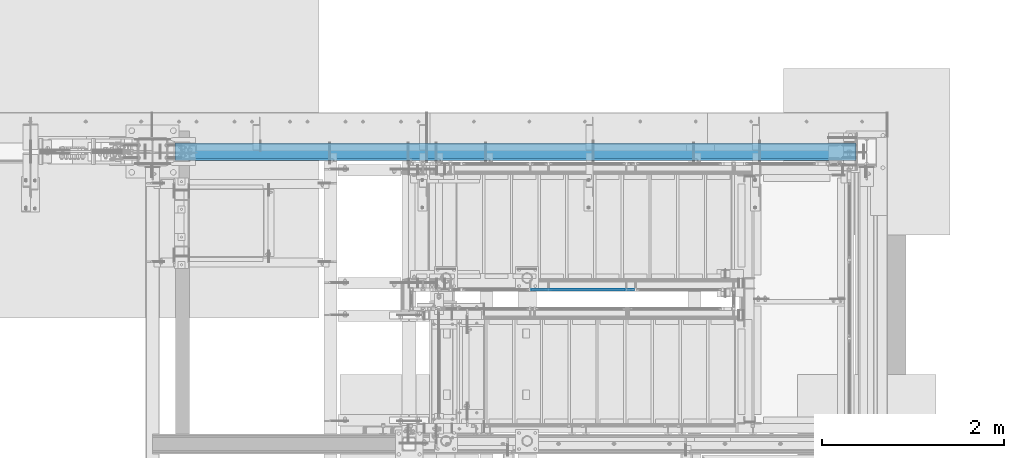
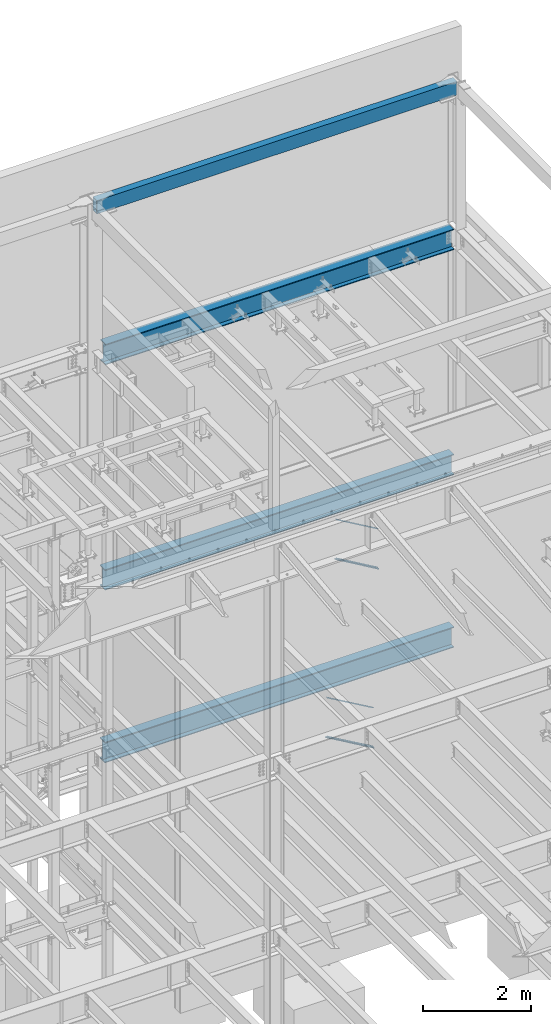
# One storey, part 793 of 1179: 8 beams, 2 members, 6 elements without a shape of their own.
"""IFC2X3 building model written with IfcOpenShell, lengths in millimetres."""

from ifc_helpers import new_model, si_unit, frame, origin_with_axes, place, context, subcontext, project, spatial, faceted_brep, material, type_object, element, aggregate, save


model = new_model("IFC2X3")

# Units and contexts
model_context = context("Model", 3, precision=1e-05, world=origin_with_axes())
body_context = subcontext(model_context, "Body", "Model", "MODEL_VIEW")
ifc_project = project(units=[si_unit("LENGTHUNIT", "METRE", prefix="MILLI"), si_unit("AREAUNIT", "SQUARE_METRE"), si_unit("VOLUMEUNIT", "CUBIC_METRE"), si_unit("MASSUNIT", "GRAM", prefix="KILO"), si_unit("TIMEUNIT", "SECOND"), si_unit("PLANEANGLEUNIT", "RADIAN"), si_unit("SOLIDANGLEUNIT", "STERADIAN"), si_unit("THERMODYNAMICTEMPERATUREUNIT", "DEGREE_CELSIUS"), si_unit("LUMINOUSINTENSITYUNIT", "LUMEN")], contexts=[model_context])

# Site, building, storey
site_placement = place(None, origin_with_axes())
site = spatial("IfcSite", under=ifc_project, at=site_placement, CompositionType="ELEMENT")
building_placement = place(site_placement, origin_with_axes())
building = spatial("IfcBuilding", under=site, at=building_placement, Name="Undefined", CompositionType="ELEMENT")
storey_placement = place(building_placement, origin_with_axes())
storey = spatial("IfcBuildingStorey", under=building, at=storey_placement, Name="Undefined", CompositionType="ELEMENT", Elevation=0.0)

# Assembly, beams
assembly_1_placement = place(storey_placement, origin_with_axes())
assembly_1 = element("IfcElementAssembly", 1, at=assembly_1_placement, inside=storey, Name="GUARDRAIL", AssemblyPlace="NOTDEFINED", PredefinedType="RIGID_FRAME")
ifc_material_1 = material(Name="STEEL/BUY-OUT")
beam_type_1 = type_object("IfcBeamType", PredefinedType="NOTDEFINED")
beam_1_placement = place(assembly_1_placement, frame((21301.2621914771, 39677.9751661883, 7438.18027204418), z_axis=(0.863778851027978, 0.0, -0.503871111016285), x_axis=(-0.503871111016286, 0.0, -0.863778851027978)))
beam_1 = element("IfcBeam", 2, at=beam_1_placement, type_object=beam_type_1, material=ifc_material_1, Name="U-EDGE", context=body_context, shape_type="Brep", body=[
    faceted_brep([(5.85307134315372e-07, 7.9375000095315, 493.146654191507), (25.4000002943358, 7.93750001315493, 537.368999999748), (25.4000002935682, 7.93749998683779, -537.369000000126), (5.89814590057358e-07, 7.93749998989369, -522.778334533057), (5.85307134315372e-07, 4.76250000952859, 493.146654191507), (5.89814590057358e-07, 4.76249998989806, -522.778334533057), (22.2250002943329, 4.76250001302105, 531.841205669258), (22.2250002935725, 4.76249998688581, -535.543713894371), (22.2250003046174, 1.58750000000146, 531.841205687164), (22.2250002832152, 1.58750000000146, -535.543713888419), (3.49245965480804e-10, 1.58750000000146, 493.146653173078), (-3.78349795937538e-10, 1.58750000000146, -522.778334194069), (3.49245965480804e-10, -1.58750000000146, 493.146653173078), (-3.78349795937538e-10, -1.58750000000146, -522.778334194069), (25.4000003047295, -1.58750000000146, 537.368999999901), (25.4000002831781, -1.58750000000146, -537.36899999997)], [[[0, 1, 2, 3]], [[4, 0, 3, 5]], [[6, 4, 5, 7]], [[8, 6, 7, 9]], [[10, 8, 9, 11]], [[12, 10, 11, 13]], [[14, 12, 13, 15]], [[11, 9, 7, 5, 3, 2, 15, 13]], [[1, 14, 15, 2]], [[0, 4, 6, 8, 10, 12, 14, 1]]]),
])
beam_2_placement = place(assembly_1_placement, frame((21275.6655141303, 39677.9751661883, 8303.16114851575), z_axis=(0.863778851027978, 0.0, -0.503871111016285), x_axis=(0.503871025088838, 0.0, 0.863778901152328)))
beam_2 = element("IfcBeam", 3, at=beam_2_placement, type_object=beam_type_1, material=ifc_material_1, Name="U-EDGE", context=body_context, shape_type="Brep", body=[
    faceted_brep([(8.44738679006696e-09, -4.76249999999709, -493.146660186705), (8.44738679006696e-09, -7.9375, -493.146660186705), (8.65475158207119e-09, -7.9375, 522.779993519576), (8.65475158207119e-09, -4.76249999999709, 522.779993519576), (22.2250000040658, -4.76249999999709, -531.84120750705), (22.2250000042877, -4.76249999999709, 535.54537418879), (22.2250000040658, -1.58750000000146, -531.84120750705), (22.2250000042877, -1.58750000000146, 535.54537418879), (-1.01863406598568e-10, -1.58750000000146, -493.146660171822), (1.09139364212751e-10, -1.58750000000146, 522.779993514665), (-1.01863406598568e-10, 1.58750000000146, -493.146660171822), (1.09139364212751e-10, 1.58750000000146, 522.779993514665), (25.4000000040614, 1.58750000000146, -537.368999999624), (25.400000004287, 1.58750000000146, 537.368999999613), (25.4000000040614, -7.9375, -537.368999999624), (25.400000004287, -7.9375, 537.368999999613)], [[[0, 1, 2, 3]], [[4, 0, 3, 5]], [[6, 4, 5, 7]], [[8, 6, 7, 9]], [[10, 8, 9, 11]], [[12, 10, 11, 13]], [[14, 12, 13, 15]], [[11, 9, 7, 5, 3, 2, 15, 13]], [[1, 14, 15, 2]], [[0, 4, 6, 8, 10, 12, 14, 1]]]),
])

assembly_2_placement = place(storey_placement, origin_with_axes())
assembly_2 = element("IfcElementAssembly", 4, at=assembly_2_placement, inside=storey, Name="GUARDRAIL", AssemblyPlace="NOTDEFINED", PredefinedType="RIGID_FRAME")
beam_3_placement = place(assembly_2_placement, frame((21150.1372838082, 39677.9751661867, 3443.58608981394), z_axis=(0.86540914081268, 0.0, -0.501065882891521), x_axis=(-0.501065882891527, 0.0, -0.865409140812677)))
beam_3 = element("IfcBeam", 5, at=beam_3_placement, type_object=beam_type_1, material=ifc_material_1, Name="U-EDGE", context=body_context, shape_type="Brep", body=[
    faceted_brep([(-2.17914930544794e-09, 1.58750000000146, -579.8750616161), (-2.17914930544794e-09, -1.58750000000146, -579.8750616161), (2.06819095183164e-09, -1.58750000000146, 550.462303003866), (2.06819095183164e-09, 1.58750000000146, 550.462303003866), (22.2250000220702, 1.58750000000146, -592.688577145202), (22.225000051898, 1.58750000000146, 589.01191290709), (22.225000034794, 4.76249998386629, -592.688577152541), (22.2250000392505, 4.7625000160333, 589.011912885151), (7.50696926843375e-08, 4.76249998754065, -579.875061660634), (7.28450686438009e-08, 4.7625000118278, 550.462303126626), (7.50696926843375e-08, 7.93749998753628, -579.875061660634), (7.28450686438009e-08, 7.93750001182343, 550.462303126626), (25.4000000347896, 7.93749998381099, -594.518999999977), (25.4000000343149, 7.9375, 594.519), (25.4000000220258, -1.58750000000146, -594.518999999807), (25.4000000343149, -1.58750000000146, 594.519)], [[[0, 1, 2, 3]], [[4, 0, 3, 5]], [[6, 4, 5, 7]], [[8, 6, 7, 9]], [[10, 8, 9, 11]], [[12, 10, 11, 13]], [[14, 12, 13, 15]], [[11, 9, 7, 5, 3, 2, 15, 13]], [[1, 14, 15, 2]], [[0, 4, 6, 8, 10, 12, 14, 1]]]),
])
beam_4_placement = place(assembly_2_placement, frame((21124.6831741915, 39677.9751661867, 4309.2613638706), z_axis=(0.86540914081268, 0.0, -0.501065882891521), x_axis=(0.501065882891522, 0.0, 0.865409140812679)))
beam_4 = element("IfcBeam", 6, at=beam_4_placement, type_object=beam_type_1, material=ifc_material_1, Name="U-EDGE", context=body_context, shape_type="Brep", body=[
    faceted_brep([(-5.08043740410358e-09, -4.76250001176231, -550.462297073285), (-5.08043740410358e-09, -7.93750001176522, -550.462297073285), (2.06819095183164e-09, -7.93749998760177, 579.875144306196), (2.06819095183164e-09, -4.76249998760613, 579.875144306196), (22.2249999989635, -4.76250001590233, -589.011912123857), (22.2249999997566, -4.76249998399726, 592.68851804268), (22.2250000115582, -1.58750000000146, -589.011912145696), (22.2249999870892, -1.58750000000146, 592.68851803538), (-3.47426976077259e-10, -1.58750000000146, -550.462297081494), (3.69254848919809e-10, -1.58750000000146, 579.875144305217), (-3.47426976077259e-10, 1.58750000000146, -550.462297081494), (3.69254848919809e-10, 1.58750000000146, 579.875144305217), (25.4000001784334, 1.58750000000146, -594.51900000087), (25.3999999489688, 1.58750000000146, 594.519), (25.4000002532193, -7.93749990531796, -594.51900000187), (25.3999999489688, -7.9375, 594.519)], [[[0, 1, 2, 3]], [[4, 0, 3, 5]], [[6, 4, 5, 7]], [[8, 6, 7, 9]], [[10, 8, 9, 11]], [[12, 10, 11, 13]], [[14, 12, 13, 15]], [[11, 9, 7, 5, 3, 2, 15, 13]], [[1, 14, 15, 2]], [[0, 4, 6, 8, 10, 12, 14, 1]]]),
])

# Member
ifc_material_2 = material(Name="STEEL/A36")
member_type = type_object("IfcMemberType", PredefinedType="NOTDEFINED")
member_1_placement = place(assembly_1_placement, frame((20810.0083338424, 39681.1500007796, 7686.14841477758), z_axis=(0.0, -1.0, 0.0), x_axis=(0.863778851027978, 0.0, -0.503871111016285)))
member_1 = element("IfcMember", 7, at=member_1_placement, type_object=member_type, material=ifc_material_2, Name="BOTTOM_RAIL", context=body_context, shape_type="Brep", body=[
    faceted_brep([(1096.61501763624, -6.34999999974752, 12.6999999999971), (1096.61501763624, -6.34999999974752, -12.6999999999971), (1089.20668431148, 6.35000000024229, -12.6999999999971), (1089.20668431148, 6.35000000024229, 12.6999999999971), (18.4070032121654, -6.34999999999127, -12.6999999999971), (18.4070032121654, -6.34999999999127, 12.6999999999971), (10.9986698874163, 6.34999999999854, 12.6999999999971), (10.9986698874163, 6.34999999999854, -12.6999999999971)], [[[0, 1, 2, 3]], [[4, 5, 6, 7]], [[6, 5, 0, 3]], [[7, 6, 3, 2]], [[4, 7, 2, 1]], [[5, 4, 1, 0]]]),
])

aggregate(assembly_1, [beam_1, beam_2, member_1])

member_2_placement = place(assembly_2_placement, frame((20608.9249611447, 39681.150000778, 3718.62097896639), z_axis=(0.0, -1.0, 0.0), x_axis=(0.86540914081268, 0.0, -0.501065882891521)))
member_2 = element("IfcMember", 8, at=member_2_placement, type_object=member_type, material=ifc_material_2, Name="BOTTOM_RAIL", context=body_context, shape_type="Brep", body=[
    faceted_brep([(10.998533752896, 6.34999999999854, -12.6999999999971), (10.998533752896, 6.34999999999854, 12.6999999999971), (1203.35358848741, 6.35000000053878, 12.6999999999971), (1203.35358848741, 6.35000000053878, -12.6999999999971), (18.3517455606161, -6.34999999998945, 12.6999999999971), (1210.70680029513, -6.34999999944921, 12.6999999999971), (18.3517455606161, -6.34999999998945, -12.6999999999971), (1210.70680029513, -6.34999999944921, -12.6999999999971)], [[[0, 1, 2, 3]], [[1, 4, 5, 2]], [[4, 6, 7, 5]], [[6, 0, 3, 7]], [[5, 7, 3, 2]], [[6, 4, 1, 0]]]),
])

aggregate(assembly_2, [beam_3, beam_4, member_2])

# Assembly, beam
assembly_3_placement = place(storey_placement, origin_with_axes())
assembly_3 = element("IfcElementAssembly", 9, at=assembly_3_placement, inside=storey, Name="BEAM", AssemblyPlace="NOTDEFINED", PredefinedType="RIGID_FRAME")
ifc_material_3 = material()
beam_type_2 = type_object("IfcBeamType", Name="HSS12X6X3/8", PredefinedType="NOTDEFINED")
beam_5_placement = place(assembly_3_placement, frame((16536.9875, 41198.8, 16275.05), z_axis=(0.0, 0.0, 1.0), x_axis=(1.0, 0.0, 0.0)))
beam_5 = element("IfcBeam", 10, at=beam_5_placement, type_object=beam_type_2, material=ifc_material_3, Name="BEAM", ObjectType="HSS12X6X3/8", context=body_context, shape_type="Brep", body=[
    faceted_brep([(9.52500000000146, 66.675, -142.875), (9.52500000000146, -66.675, -142.875), (7734.29999999999, -66.6750000000029, -142.875), (7734.29999999999, 66.6750000000029, -142.875), (9.52500000000146, -66.675, 142.875000000002), (7734.29999999999, -66.6750000000029, 142.875000000002), (9.52500000000146, 66.675, 142.875000000002), (7734.29999999999, 66.6750000000029, 142.875000000002), (9.52500000000146, 76.2, -152.4), (9.52500000000146, 76.2, 152.4), (7734.29999999999, 76.1999999999971, 152.4), (7734.29999999999, 76.1999999999971, -152.4), (9.52500000000146, -76.2, 152.4), (7734.29999999999, -76.1999999999971, 152.4), (9.52500000000146, -76.2, -152.4), (7734.29999999999, -76.1999999999971, -152.4)], [[[0, 1, 2, 3]], [[1, 4, 5, 2]], [[4, 6, 7, 5]], [[6, 0, 3, 7]], [[8, 9, 10, 11]], [[9, 12, 13, 10]], [[12, 14, 15, 13]], [[14, 8, 11, 15]], [[13, 15, 11, 10], [5, 7, 3, 2]], [[14, 12, 9, 8], [6, 4, 1, 0]]]),
])
aggregate(assembly_3, [beam_5])

assembly_4_placement = place(storey_placement, origin_with_axes())
assembly_4 = element("IfcElementAssembly", 11, at=assembly_4_placement, inside=storey, Name="BEAM", AssemblyPlace="NOTDEFINED", PredefinedType="RIGID_FRAME")
ifc_material_4 = material(Name="STEEL/A992")
beam_type_3 = type_object("IfcBeamType", Name="W18X65", PredefinedType="NOTDEFINED")
beam_6_placement = place(assembly_4_placement, frame((16459.2, 41198.8, 12885.7375), z_axis=(0.0, 0.0, 1.0), x_axis=(1.0, 0.0, 0.0)))
beam_6 = element("IfcBeam", 12, at=beam_6_placement, type_object=beam_type_3, material=ifc_material_4, Name="BEAM", ObjectType="W18X65", context=body_context, shape_type="Brep", body=[
    faceted_brep([(260.349999999999, -96.8375000000015, -233.362499999999), (260.349999999999, 96.8375000000015, -233.362499999999), (7732.71250000001, 96.8375000000015, -233.362499999999), (7732.71250000001, -96.8375000000015, -233.362499999999), (260.349999999999, -96.8375000000015, -214.3125), (260.349999999999, -5.55625000000146, -214.3125), (260.349999999999, -5.55625000000146, -122.977499999975), (260.349999999999, -5.55625000000146, 183.302500000125), (260.349999999999, -5.55625000000146, 214.3125), (260.349999999999, -96.8375000000015, 214.3125), (260.349999999999, -96.8375000000015, 233.362499999999), (260.349999999999, 96.8375000000015, 233.362499999999), (260.349999999999, 96.8375000000015, 214.3125), (260.349999999999, 5.55625000000146, 214.3125), (260.349999999999, 5.55625000000146, -214.3125), (260.349999999999, 96.8375000000015, -214.3125), (7732.71250000001, -96.8375000000015, -214.3125), (7732.71250000001, -5.55625000000146, -214.3125), (7732.71250000001, -5.55625000000146, -129.327499999972), (7732.71250000001, -5.55625000000146, 189.652500000135), (7732.71250000001, -5.55625000000146, 214.3125), (7732.71250000001, -96.8375000000015, 214.3125), (7732.71250000001, -96.8375000000015, 233.362499999999), (7732.71250000001, 96.8375000000015, 233.362499999999), (7732.71250000001, 96.8375000000015, 214.3125), (7732.71250000001, 5.55625000000146, 214.3125), (7732.71250000001, 5.55625000000146, -214.3125), (7732.71250000001, 96.8375000000015, -214.3125)], [[[0, 1, 2, 3]], [[0, 4, 5, 6, 7, 8, 9, 10, 11, 12, 13, 14, 15, 1]], [[5, 4, 16, 17]], [[8, 7, 6, 5, 17, 18, 19, 20]], [[9, 8, 20, 21]], [[10, 9, 21, 22]], [[11, 10, 22, 23]], [[12, 11, 23, 24]], [[13, 12, 24, 25]], [[14, 13, 25, 26]], [[15, 14, 26, 27]], [[1, 15, 27, 2]], [[26, 25, 24, 23, 22, 21, 20, 19, 18, 17, 16, 3, 2, 27]], [[4, 0, 3, 16]]]),
])
aggregate(assembly_4, [beam_6])

assembly_5_placement = place(storey_placement, origin_with_axes())
assembly_5 = element("IfcElementAssembly", 13, at=assembly_5_placement, inside=storey, Name="BEAM", AssemblyPlace="NOTDEFINED", PredefinedType="RIGID_FRAME")
beam_7_placement = place(assembly_5_placement, frame((16459.2, 41198.8, 7780.3375), z_axis=(0.0, 0.0, 1.0), x_axis=(1.0, 0.0, 0.0)))
beam_7 = element("IfcBeam", 14, at=beam_7_placement, type_object=beam_type_3, material=ifc_material_4, Name="BEAM", ObjectType="W18X65", context=body_context, shape_type="Brep", body=[
    faceted_brep([(247.650000000016, -96.8375000000015, -233.362499999999), (247.650000000016, 96.8375000000015, -233.362499999999), (7732.71250000001, 96.8375000000015, -233.362499999999), (7732.71250000001, -96.8375000000015, -233.362499999999), (247.650000000016, -96.8375000000015, -214.3125), (247.650000000016, -5.55625000000146, -214.3125), (247.650000000016, -5.55625000000146, 214.3125), (247.650000000016, -96.8375000000015, 214.3125), (247.650000000016, -96.8375000000015, 233.362499999999), (247.650000000016, 96.8375000000015, 233.362499999999), (247.650000000016, 96.8375000000015, 214.3125), (247.650000000016, 5.55625000000146, 214.3125), (247.650000000016, 5.55625000000146, 196.00250000013), (247.650000000016, 5.55625000000146, -110.277499999971), (247.650000000016, 5.55625000000146, -214.3125), (247.650000000016, 96.8375000000015, -214.3125), (7732.71250000001, -96.8375000000015, -214.3125), (7732.71250000001, -5.55625000000146, -214.3125), (7732.7125, -5.55625000000146, -110.277499999968), (7732.7125, -5.55625000000146, 196.002500000134), (7732.71250000001, -5.55625000000146, 214.3125), (7732.71250000001, -96.8375000000015, 214.3125), (7732.71250000001, -96.8375000000015, 233.362499999999), (7732.71250000001, 96.8375000000015, 233.362499999999), (7732.71250000001, 96.8375000000015, 214.3125), (7732.71250000001, 5.55625000000146, 214.3125), (7732.71250000001, 5.55625000000146, -214.3125), (7732.71250000001, 96.8375000000015, -214.3125)], [[[0, 1, 2, 3]], [[0, 4, 5, 6, 7, 8, 9, 10, 11, 12, 13, 14, 15, 1]], [[5, 4, 16, 17]], [[6, 5, 17, 18, 19, 20]], [[7, 6, 20, 21]], [[8, 7, 21, 22]], [[9, 8, 22, 23]], [[10, 9, 23, 24]], [[11, 10, 24, 25]], [[14, 13, 12, 11, 25, 26]], [[15, 14, 26, 27]], [[1, 15, 27, 2]], [[26, 25, 24, 23, 22, 21, 20, 19, 18, 17, 16, 3, 2, 27]], [[4, 0, 3, 16]]]),
])
aggregate(assembly_5, [beam_7])

assembly_6_placement = place(storey_placement, origin_with_axes())
assembly_6 = element("IfcElementAssembly", 15, at=assembly_6_placement, inside=storey, Name="BEAM", AssemblyPlace="NOTDEFINED", PredefinedType="RIGID_FRAME")
beam_8_placement = place(assembly_6_placement, frame((16459.2, 41198.8, 3868.7375), z_axis=(0.0, 0.0, 1.0), x_axis=(1.0, 0.0, 0.0)))
beam_8 = element("IfcBeam", 16, at=beam_8_placement, type_object=beam_type_3, material=ifc_material_4, Name="BEAM", ObjectType="W18X65", context=body_context, shape_type="Brep", body=[
    faceted_brep([(247.650000000016, -96.8375000000015, -233.362499999999), (247.650000000016, 96.8375000000015, -233.362499999999), (7732.71250000001, 96.8375000000015, -233.362499999999), (7732.71250000001, -96.8375000000015, -233.362499999999), (247.650000000016, -96.8375000000015, -214.3125), (247.650000000016, -5.55625000000146, -214.3125), (247.650000000016, -5.55625000000146, 214.3125), (247.650000000016, -96.8375000000015, 214.3125), (247.650000000016, -96.8375000000015, 233.362499999999), (247.650000000016, 96.8375000000015, 233.362499999999), (247.650000000016, 96.8375000000015, 214.3125), (247.650000000016, 5.55625000000146, 214.3125), (247.650000000001, 5.55625000000146, 183.302500000156), (247.650000000001, 5.55625000000146, -122.97749999995), (247.650000000016, 5.55625000000146, -214.3125), (247.650000000016, 96.8375000000015, -214.3125), (7732.71250000001, -96.8375000000015, -214.3125), (7732.71250000001, -5.55625000000146, -214.3125), (7732.7125, -5.55625000000146, -122.9775), (7732.7125, -5.55625000000146, 183.3025), (7732.71250000001, -5.55625000000146, 214.3125), (7732.71250000001, -96.8375000000015, 214.3125), (7732.71250000001, -96.8375000000015, 233.362499999999), (7732.71250000001, 96.8375000000015, 233.362499999999), (7732.71250000001, 96.8375000000015, 214.3125), (7732.71250000001, 5.55625000000146, 214.3125), (7732.71250000001, 5.55625000000146, -214.3125), (7732.71250000001, 96.8375000000015, -214.3125)], [[[0, 1, 2, 3]], [[0, 4, 5, 6, 7, 8, 9, 10, 11, 12, 13, 14, 15, 1]], [[5, 4, 16, 17]], [[6, 5, 17, 18, 19, 20]], [[7, 6, 20, 21]], [[8, 7, 21, 22]], [[9, 8, 22, 23]], [[10, 9, 23, 24]], [[11, 10, 24, 25]], [[14, 13, 12, 11, 25, 26]], [[15, 14, 26, 27]], [[1, 15, 27, 2]], [[26, 25, 24, 23, 22, 21, 20, 19, 18, 17, 16, 3, 2, 27]], [[4, 0, 3, 16]]]),
])
aggregate(assembly_6, [beam_8])

save(model, "model.ifc")
